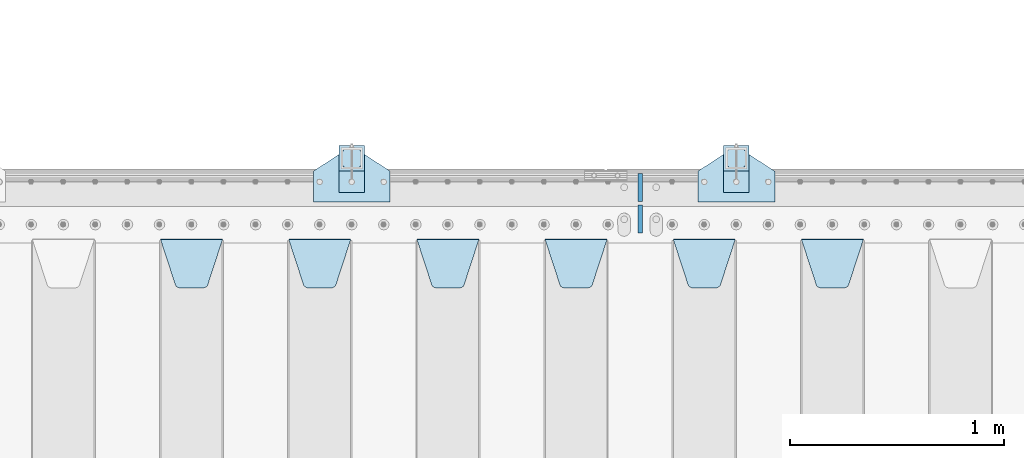
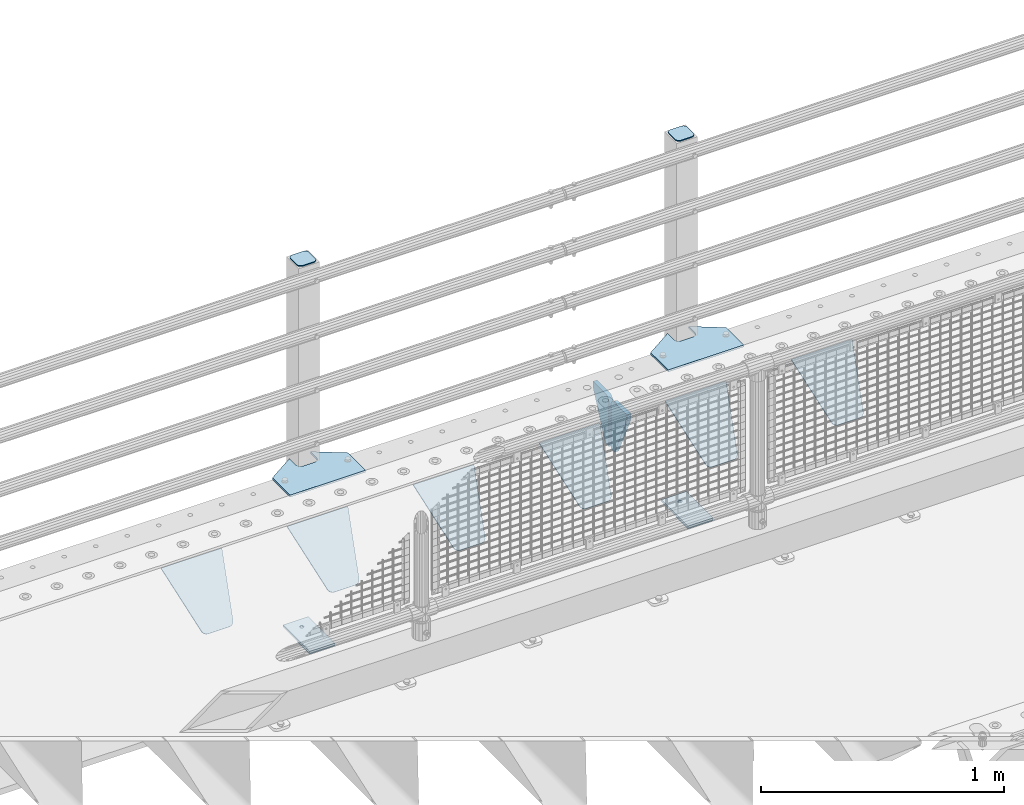
# One storey, part 175 of 208: 16 plates.
"""IFC2X3 building model written with IfcOpenShell, lengths in millimetres."""

from ifc_helpers import new_model, si_unit, frame, origin_with_axes, place, context, subcontext, project, spatial, faceted_brep, material, type_object, element, save


model = new_model("IFC2X3")

# Units and contexts
model_context = context("Model", 3, precision=1e-05, world=origin_with_axes())
body_context = subcontext(model_context, "Body", "Model", "MODEL_VIEW")
ifc_project = project(units=[si_unit("LENGTHUNIT", "METRE", prefix="MILLI"), si_unit("AREAUNIT", "SQUARE_METRE"), si_unit("VOLUMEUNIT", "CUBIC_METRE"), si_unit("MASSUNIT", "GRAM", prefix="KILO"), si_unit("TIMEUNIT", "SECOND"), si_unit("PLANEANGLEUNIT", "RADIAN"), si_unit("SOLIDANGLEUNIT", "STERADIAN"), si_unit("THERMODYNAMICTEMPERATUREUNIT", "DEGREE_CELSIUS"), si_unit("LUMINOUSINTENSITYUNIT", "LUMEN")], contexts=[model_context])

# Site, building, storey
site_placement = place(None, origin_with_axes())
site = spatial("IfcSite", under=ifc_project, at=site_placement, CompositionType="ELEMENT")
building_placement = place(site_placement, origin_with_axes())
building = spatial("IfcBuilding", under=site, at=building_placement, Name="Standard", CompositionType="ELEMENT")
storey_placement = place(building_placement, origin_with_axes())
storey = spatial("IfcBuildingStorey", under=building, at=storey_placement, Name="Undefined", CompositionType="ELEMENT", Elevation=0.0)

# Plates
ifc_material_1 = material(Name="STEEL/S355N")
plate_type_1 = type_object("IfcPlateType", PredefinedType="NOTDEFINED")
plate_1_placement = place(storey_placement, frame((-36195.0, 5831.76776695596, -1.76776695296758), z_axis=(0.0, -0.707106781186548, -0.707106781186547), x_axis=(1.0, 0.0, 0.0)))
element("IfcPlate", 1, at=plate_1_placement, inside=storey, type_object=plate_type_1, material=ifc_material_1, context=body_context, shape_type="Brep", body=[
    faceted_brep([(0.0, -2.5, 0.0), (69.345504679477, -2.5, 300.17173142483), (69.345504679477, 2.5, 300.17173142483), (0.0, 2.5, 0.0), (70.9274061199576, -2.5, 304.897442415399), (70.9274061199576, 2.5, 304.8974424154), (73.3818627772307, -2.5, 309.234538108527), (73.3818627772307, 2.5, 309.234538108527), (76.6187032999551, -2.5, 313.023683126103), (76.6187032999551, 2.5, 313.023683126103), (80.5190132704993, -2.5, 316.125672595371), (80.5190132704993, 2.5, 316.125672595371), (84.9395038596849, -2.5, 318.426546230476), (84.9395038596849, 2.50000000000091, 318.426546230476), (89.7177759439219, -2.5, 319.841774983275), (89.7177759439219, 2.50000000000091, 319.841774983275), (94.678286292652, -2.49999999999909, 320.319366455078), (94.678286292652, 2.5, 320.319366455078), (195.321713707348, -2.49999999999909, 320.319366455078), (195.321713707348, 2.5, 320.319366455078), (200.282224056078, -2.5, 319.841774983275), (200.282224056078, 2.5, 319.841774983274), (205.060496140315, -2.5, 318.426546230475), (205.060496140315, 2.5, 318.426546230475), (209.480986729501, -2.5, 316.125672595371), (209.480986729501, 2.50000000000091, 316.125672595371), (213.381296700045, -2.5, 313.023683126102), (213.381296700045, 2.5, 313.023683126102), (216.618137222769, -2.5, 309.234538108526), (216.618137222769, 2.5, 309.234538108527), (219.072593880042, -2.5, 304.897442415399), (219.072593880042, 2.5, 304.897442415399), (220.654495320523, -2.5, 300.17173142483), (220.654495320523, 2.5, 300.17173142483), (290.0, -2.5, 0.0), (290.0, 2.5, 0.0)], [[[0, 1, 2, 3]], [[1, 4, 5, 2]], [[4, 6, 7, 5]], [[6, 8, 9, 7]], [[8, 10, 11, 9]], [[10, 12, 13, 11]], [[12, 14, 15, 13]], [[14, 16, 17, 15]], [[16, 18, 19, 17]], [[18, 20, 21, 19]], [[20, 22, 23, 21]], [[22, 24, 25, 23]], [[24, 26, 27, 25]], [[26, 28, 29, 27]], [[28, 30, 31, 29]], [[30, 32, 33, 31]], [[32, 34, 35, 33]], [[34, 0, 3, 35]], [[5, 7, 9, 11, 13, 15, 17, 19, 21, 23, 25, 27, 29, 31, 33, 35, 3, 2]], [[34, 32, 30, 28, 26, 24, 22, 20, 18, 16, 14, 12, 10, 8, 6, 4, 1, 0]]]),
])
plate_2_placement = place(storey_placement, frame((-36795.0, 5831.76776695596, -1.76776695296758), z_axis=(0.0, -0.707106781186548, -0.707106781186547), x_axis=(1.0, 0.0, 0.0)))
element("IfcPlate", 2, at=plate_2_placement, inside=storey, type_object=plate_type_1, material=ifc_material_1, context=body_context, shape_type="Brep", body=[
    faceted_brep([(0.0, -2.5, 0.0), (69.345504679477, -2.5, 300.17173142483), (69.345504679477, 2.5, 300.17173142483), (0.0, 2.5, 0.0), (70.9274061199576, -2.5, 304.897442415399), (70.9274061199576, 2.5, 304.8974424154), (73.3818627772307, -2.5, 309.234538108527), (73.3818627772307, 2.5, 309.234538108527), (76.6187032999551, -2.5, 313.023683126103), (76.6187032999551, 2.5, 313.023683126103), (80.5190132704993, -2.5, 316.125672595371), (80.5190132704993, 2.5, 316.125672595371), (84.9395038596849, -2.5, 318.426546230476), (84.9395038596849, 2.50000000000091, 318.426546230476), (89.7177759439219, -2.5, 319.841774983275), (89.7177759439219, 2.50000000000091, 319.841774983275), (94.678286292652, -2.49999999999909, 320.319366455078), (94.678286292652, 2.5, 320.319366455078), (195.321713707348, -2.49999999999909, 320.319366455078), (195.321713707348, 2.5, 320.319366455078), (200.282224056078, -2.5, 319.841774983275), (200.282224056078, 2.5, 319.841774983274), (205.060496140315, -2.5, 318.426546230475), (205.060496140315, 2.5, 318.426546230475), (209.480986729501, -2.5, 316.125672595371), (209.480986729501, 2.50000000000091, 316.125672595371), (213.381296700045, -2.5, 313.023683126102), (213.381296700045, 2.5, 313.023683126102), (216.618137222769, -2.5, 309.234538108526), (216.618137222769, 2.5, 309.234538108527), (219.072593880042, -2.5, 304.897442415399), (219.072593880042, 2.5, 304.897442415399), (220.654495320523, -2.5, 300.17173142483), (220.654495320523, 2.5, 300.17173142483), (290.0, -2.5, 0.0), (290.0, 2.5, 0.0)], [[[0, 1, 2, 3]], [[1, 4, 5, 2]], [[4, 6, 7, 5]], [[6, 8, 9, 7]], [[8, 10, 11, 9]], [[10, 12, 13, 11]], [[12, 14, 15, 13]], [[14, 16, 17, 15]], [[16, 18, 19, 17]], [[18, 20, 21, 19]], [[20, 22, 23, 21]], [[22, 24, 25, 23]], [[24, 26, 27, 25]], [[26, 28, 29, 27]], [[28, 30, 31, 29]], [[30, 32, 33, 31]], [[32, 34, 35, 33]], [[34, 0, 3, 35]], [[5, 7, 9, 11, 13, 15, 17, 19, 21, 23, 25, 27, 29, 31, 33, 35, 3, 2]], [[34, 32, 30, 28, 26, 24, 22, 20, 18, 16, 14, 12, 10, 8, 6, 4, 1, 0]]]),
])
plate_3_placement = place(storey_placement, frame((-37395.0, 5831.76776695596, -1.76776695296758), z_axis=(0.0, -0.707106781186548, -0.707106781186547), x_axis=(1.0, 0.0, 0.0)))
element("IfcPlate", 3, at=plate_3_placement, inside=storey, type_object=plate_type_1, material=ifc_material_1, context=body_context, shape_type="Brep", body=[
    faceted_brep([(0.0, -2.5, 0.0), (69.345504679477, -2.5, 300.17173142483), (69.345504679477, 2.5, 300.17173142483), (0.0, 2.5, 0.0), (70.9274061199576, -2.5, 304.897442415399), (70.9274061199576, 2.5, 304.8974424154), (73.3818627772307, -2.5, 309.234538108527), (73.3818627772307, 2.5, 309.234538108527), (76.6187032999551, -2.5, 313.023683126103), (76.6187032999551, 2.5, 313.023683126103), (80.5190132704993, -2.5, 316.125672595371), (80.5190132704993, 2.5, 316.125672595371), (84.9395038596849, -2.5, 318.426546230476), (84.9395038596849, 2.50000000000091, 318.426546230476), (89.7177759439219, -2.5, 319.841774983275), (89.7177759439219, 2.50000000000091, 319.841774983275), (94.678286292652, -2.49999999999909, 320.319366455078), (94.678286292652, 2.5, 320.319366455078), (195.321713707348, -2.49999999999909, 320.319366455078), (195.321713707348, 2.5, 320.319366455078), (200.282224056078, -2.5, 319.841774983275), (200.282224056078, 2.5, 319.841774983274), (205.060496140315, -2.5, 318.426546230475), (205.060496140315, 2.5, 318.426546230475), (209.480986729501, -2.5, 316.125672595371), (209.480986729501, 2.50000000000091, 316.125672595371), (213.381296700045, -2.5, 313.023683126102), (213.381296700045, 2.5, 313.023683126102), (216.618137222769, -2.5, 309.234538108526), (216.618137222769, 2.5, 309.234538108527), (219.072593880042, -2.5, 304.897442415399), (219.072593880042, 2.5, 304.897442415399), (220.654495320523, -2.5, 300.17173142483), (220.654495320523, 2.5, 300.17173142483), (290.0, -2.5, 0.0), (290.0, 2.5, 0.0)], [[[0, 1, 2, 3]], [[1, 4, 5, 2]], [[4, 6, 7, 5]], [[6, 8, 9, 7]], [[8, 10, 11, 9]], [[10, 12, 13, 11]], [[12, 14, 15, 13]], [[14, 16, 17, 15]], [[16, 18, 19, 17]], [[18, 20, 21, 19]], [[20, 22, 23, 21]], [[22, 24, 25, 23]], [[24, 26, 27, 25]], [[26, 28, 29, 27]], [[28, 30, 31, 29]], [[30, 32, 33, 31]], [[32, 34, 35, 33]], [[34, 0, 3, 35]], [[5, 7, 9, 11, 13, 15, 17, 19, 21, 23, 25, 27, 29, 31, 33, 35, 3, 2]], [[34, 32, 30, 28, 26, 24, 22, 20, 18, 16, 14, 12, 10, 8, 6, 4, 1, 0]]]),
])
plate_4_placement = place(storey_placement, frame((-37995.0, 5831.76776695596, -1.76776695296758), z_axis=(0.0, -0.707106781186548, -0.707106781186547), x_axis=(1.0, 0.0, 0.0)))
element("IfcPlate", 4, at=plate_4_placement, inside=storey, type_object=plate_type_1, material=ifc_material_1, context=body_context, shape_type="Brep", body=[
    faceted_brep([(0.0, -2.5, 0.0), (69.345504679477, -2.5, 300.17173142483), (69.345504679477, 2.5, 300.17173142483), (0.0, 2.5, 0.0), (70.9274061199576, -2.5, 304.897442415399), (70.9274061199576, 2.5, 304.8974424154), (73.3818627772307, -2.5, 309.234538108527), (73.3818627772307, 2.5, 309.234538108527), (76.6187032999551, -2.5, 313.023683126103), (76.6187032999551, 2.5, 313.023683126103), (80.5190132704993, -2.5, 316.125672595371), (80.5190132704993, 2.5, 316.125672595371), (84.9395038596849, -2.5, 318.426546230476), (84.9395038596849, 2.50000000000091, 318.426546230476), (89.7177759439219, -2.5, 319.841774983275), (89.7177759439219, 2.50000000000091, 319.841774983275), (94.678286292652, -2.49999999999909, 320.319366455078), (94.678286292652, 2.5, 320.319366455078), (195.321713707348, -2.49999999999909, 320.319366455078), (195.321713707348, 2.5, 320.319366455078), (200.282224056078, -2.5, 319.841774983275), (200.282224056078, 2.5, 319.841774983274), (205.060496140315, -2.5, 318.426546230475), (205.060496140315, 2.5, 318.426546230475), (209.480986729501, -2.5, 316.125672595371), (209.480986729501, 2.50000000000091, 316.125672595371), (213.381296700045, -2.5, 313.023683126102), (213.381296700045, 2.5, 313.023683126102), (216.618137222769, -2.5, 309.234538108526), (216.618137222769, 2.5, 309.234538108527), (219.072593880042, -2.5, 304.897442415399), (219.072593880042, 2.5, 304.897442415399), (220.654495320523, -2.5, 300.17173142483), (220.654495320523, 2.5, 300.17173142483), (290.0, -2.5, 0.0), (290.0, 2.5, 0.0)], [[[0, 1, 2, 3]], [[1, 4, 5, 2]], [[4, 6, 7, 5]], [[6, 8, 9, 7]], [[8, 10, 11, 9]], [[10, 12, 13, 11]], [[12, 14, 15, 13]], [[14, 16, 17, 15]], [[16, 18, 19, 17]], [[18, 20, 21, 19]], [[20, 22, 23, 21]], [[22, 24, 25, 23]], [[24, 26, 27, 25]], [[26, 28, 29, 27]], [[28, 30, 31, 29]], [[30, 32, 33, 31]], [[32, 34, 35, 33]], [[34, 0, 3, 35]], [[5, 7, 9, 11, 13, 15, 17, 19, 21, 23, 25, 27, 29, 31, 33, 35, 3, 2]], [[34, 32, 30, 28, 26, 24, 22, 20, 18, 16, 14, 12, 10, 8, 6, 4, 1, 0]]]),
])
plate_5_placement = place(storey_placement, frame((-38595.0, 5831.76776695596, -1.76776695296758), z_axis=(0.0, -0.707106781186548, -0.707106781186547), x_axis=(1.0, 0.0, 0.0)))
element("IfcPlate", 5, at=plate_5_placement, inside=storey, type_object=plate_type_1, material=ifc_material_1, context=body_context, shape_type="Brep", body=[
    faceted_brep([(0.0, -2.5, 0.0), (69.345504679477, -2.5, 300.17173142483), (69.345504679477, 2.5, 300.17173142483), (0.0, 2.5, 0.0), (70.9274061199576, -2.5, 304.897442415399), (70.9274061199576, 2.5, 304.8974424154), (73.3818627772307, -2.5, 309.234538108527), (73.3818627772307, 2.5, 309.234538108527), (76.6187032999551, -2.5, 313.023683126103), (76.6187032999551, 2.5, 313.023683126103), (80.5190132704993, -2.5, 316.125672595371), (80.5190132704993, 2.5, 316.125672595371), (84.9395038596849, -2.5, 318.426546230476), (84.9395038596849, 2.50000000000091, 318.426546230476), (89.7177759439219, -2.5, 319.841774983275), (89.7177759439219, 2.50000000000091, 319.841774983275), (94.678286292652, -2.49999999999909, 320.319366455078), (94.678286292652, 2.5, 320.319366455078), (195.321713707348, -2.49999999999909, 320.319366455078), (195.321713707348, 2.5, 320.319366455078), (200.282224056078, -2.5, 319.841774983275), (200.282224056078, 2.5, 319.841774983274), (205.060496140315, -2.5, 318.426546230475), (205.060496140315, 2.5, 318.426546230475), (209.480986729501, -2.5, 316.125672595371), (209.480986729501, 2.50000000000091, 316.125672595371), (213.381296700045, -2.5, 313.023683126102), (213.381296700045, 2.5, 313.023683126102), (216.618137222769, -2.5, 309.234538108526), (216.618137222769, 2.5, 309.234538108527), (219.072593880042, -2.5, 304.897442415399), (219.072593880042, 2.5, 304.897442415399), (220.654495320523, -2.5, 300.17173142483), (220.654495320523, 2.5, 300.17173142483), (290.0, -2.5, 0.0), (290.0, 2.5, 0.0)], [[[0, 1, 2, 3]], [[1, 4, 5, 2]], [[4, 6, 7, 5]], [[6, 8, 9, 7]], [[8, 10, 11, 9]], [[10, 12, 13, 11]], [[12, 14, 15, 13]], [[14, 16, 17, 15]], [[16, 18, 19, 17]], [[18, 20, 21, 19]], [[20, 22, 23, 21]], [[22, 24, 25, 23]], [[24, 26, 27, 25]], [[26, 28, 29, 27]], [[28, 30, 31, 29]], [[30, 32, 33, 31]], [[32, 34, 35, 33]], [[34, 0, 3, 35]], [[5, 7, 9, 11, 13, 15, 17, 19, 21, 23, 25, 27, 29, 31, 33, 35, 3, 2]], [[34, 32, 30, 28, 26, 24, 22, 20, 18, 16, 14, 12, 10, 8, 6, 4, 1, 0]]]),
])
plate_6_placement = place(storey_placement, frame((-39195.0, 5831.76776695596, -1.76776695296758), z_axis=(0.0, -0.707106781186548, -0.707106781186547), x_axis=(1.0, 0.0, 0.0)))
element("IfcPlate", 6, at=plate_6_placement, inside=storey, type_object=plate_type_1, material=ifc_material_1, context=body_context, shape_type="Brep", body=[
    faceted_brep([(0.0, -2.5, 0.0), (69.345504679477, -2.5, 300.17173142483), (69.345504679477, 2.5, 300.17173142483), (0.0, 2.5, 0.0), (70.9274061199576, -2.5, 304.897442415399), (70.9274061199576, 2.5, 304.8974424154), (73.3818627772307, -2.5, 309.234538108527), (73.3818627772307, 2.5, 309.234538108527), (76.6187032999551, -2.5, 313.023683126103), (76.6187032999551, 2.5, 313.023683126103), (80.5190132704993, -2.5, 316.125672595371), (80.5190132704993, 2.5, 316.125672595371), (84.9395038596849, -2.5, 318.426546230476), (84.9395038596849, 2.50000000000091, 318.426546230476), (89.7177759439219, -2.5, 319.841774983275), (89.7177759439219, 2.50000000000091, 319.841774983275), (94.678286292652, -2.49999999999909, 320.319366455078), (94.678286292652, 2.5, 320.319366455078), (195.321713707348, -2.49999999999909, 320.319366455078), (195.321713707348, 2.5, 320.319366455078), (200.282224056078, -2.5, 319.841774983275), (200.282224056078, 2.5, 319.841774983274), (205.060496140315, -2.5, 318.426546230475), (205.060496140315, 2.5, 318.426546230475), (209.480986729501, -2.5, 316.125672595371), (209.480986729501, 2.50000000000091, 316.125672595371), (213.381296700045, -2.5, 313.023683126102), (213.381296700045, 2.5, 313.023683126102), (216.618137222769, -2.5, 309.234538108526), (216.618137222769, 2.5, 309.234538108527), (219.072593880042, -2.5, 304.897442415399), (219.072593880042, 2.5, 304.897442415399), (220.654495320523, -2.5, 300.17173142483), (220.654495320523, 2.5, 300.17173142483), (290.0, -2.5, 0.0), (290.0, 2.5, 0.0)], [[[0, 1, 2, 3]], [[1, 4, 5, 2]], [[4, 6, 7, 5]], [[6, 8, 9, 7]], [[8, 10, 11, 9]], [[10, 12, 13, 11]], [[12, 14, 15, 13]], [[14, 16, 17, 15]], [[16, 18, 19, 17]], [[18, 20, 21, 19]], [[20, 22, 23, 21]], [[22, 24, 25, 23]], [[24, 26, 27, 25]], [[26, 28, 29, 27]], [[28, 30, 31, 29]], [[30, 32, 33, 31]], [[32, 34, 35, 33]], [[34, 0, 3, 35]], [[5, 7, 9, 11, 13, 15, 17, 19, 21, 23, 25, 27, 29, 31, 33, 35, 3, 2]], [[34, 32, 30, 28, 26, 24, 22, 20, 18, 16, 14, 12, 10, 8, 6, 4, 1, 0]]]),
])
plate_type_2 = type_object("IfcPlateType", PredefinedType="NOTDEFINED")
for number, where, z_axis, x_axis in (
    (7, (-36950.0, 6140.0, -30.0), (0.0, 0.0, -1.0), (0.0, -1.0, 0.0)),
    (8, (-36950.0, 5860.0, -30.0), (0.0, 0.0, -1.0), (0.0, 1.0, 0.0)),
):
    element("IfcPlate", number, at=place(storey_placement, frame(where, z_axis=z_axis, x_axis=x_axis)), inside=storey, type_object=plate_type_2, material=ifc_material_1, context=body_context, shape_type="Brep", body=[
        faceted_brep([(0.0, -10.0, 0.0), (0.0, -10.0, 30.0), (0.0, 10.0, 30.0), (0.0, 10.0, 0.0), (102.0, -10.0, 250.0), (102.0, 10.0, 250.0), (132.0, -10.0, 250.0), (132.0, 10.0, 250.0), (132.0, -10.0, 30.0), (132.0, 10.0, 30.0), (131.544232590366, -10.0, 24.790554669992), (131.544232590366, 10.0, 24.790554669992), (130.190778623577, -10.0, 19.7393957002299), (130.190778623577, 10.0, 19.7393957002299), (127.980762113533, -10.0, 15.0), (127.980762113533, 10.0, 15.0), (124.981333293569, -10.0, 10.7163717094038), (124.981333293569, 10.0, 10.7163717094038), (121.283628290596, -10.0, 7.01866670643062), (121.283628290596, 10.0, 7.01866670643062), (117.0, -10.0, 4.01923788646684), (117.0, 10.0, 4.01923788646684), (112.26060429977, -10.0, 1.80922137642278), (112.26060429977, 10.0, 1.80922137642278), (107.209445330008, -10.0, 0.455767409633722), (107.209445330008, 10.0, 0.455767409633722), (102.0, -10.0, 0.0), (102.0, 10.0, 0.0)], [[[0, 1, 2, 3]], [[1, 4, 5, 2]], [[4, 6, 7, 5]], [[6, 8, 9, 7]], [[8, 10, 11, 9]], [[10, 12, 13, 11]], [[12, 14, 15, 13]], [[14, 16, 17, 15]], [[16, 18, 19, 17]], [[18, 20, 21, 19]], [[20, 22, 23, 21]], [[22, 24, 25, 23]], [[24, 26, 27, 25]], [[26, 0, 3, 27]], [[5, 7, 9, 11, 13, 15, 17, 19, 21, 23, 25, 27, 3, 2]], [[26, 24, 22, 20, 18, 16, 14, 12, 10, 8, 6, 4, 1, 0]]]),
    ])
ifc_material_2 = material(Name="STEEL/S355J2")
plate_type_3 = type_object("IfcPlateType", PredefinedType="NOTDEFINED")
plate_7_placement = place(storey_placement, frame((-36680.0, 6005.0, 5.00000000004911), z_axis=(0.0, 1.0, 0.0), x_axis=(1.0, 0.0, 0.0)))
element("IfcPlate", 9, at=plate_7_placement, inside=storey, type_object=plate_type_3, material=ifc_material_2, context=body_context, shape_type="Brep", body=[
    faceted_brep([(0.0, -5.0, 0.0), (2.31396552408114e-06, -5.0, 145.0), (2.31396552408114e-06, 5.0, 145.0), (0.0, 5.0, 0.0), (130.0, -5.0, 230.0), (130.0, 5.0, 230.0), (130.0, -5.0, 180.0), (130.0, 5.0, 180.0), (130.48036798992, -5.0, 175.122741949597), (130.48036798992, 5.0, 175.122741949597), (131.903011687216, -5.0, 170.432914190873), (131.903011687216, 5.0, 170.432914190873), (134.213259692435, -5.0, 166.11074417451), (134.213259692435, 5.0, 166.11074417451), (137.322330470335, -5.0, 162.322330470336), (137.322330470335, 5.0, 162.322330470336), (141.110744174512, -5.0, 159.213259692437), (141.110744174512, 5.0, 159.213259692437), (145.432914190871, -5.0, 156.903011687218), (145.432914190871, 5.0, 156.903011687218), (150.122741949595, -5.0, 155.48036798992), (150.122741949595, 5.0, 155.48036798992), (155.0, -5.0, 155.0), (155.0, 5.0, 155.0), (205.0, -5.0, 155.0), (205.0, 5.0, 155.0), (209.877258050405, -5.0, 155.48036798992), (209.877258050405, 5.0, 155.48036798992), (214.567085809129, -5.0, 156.903011687218), (214.567085809129, 5.0, 156.903011687218), (218.889255825488, -5.0, 159.213259692437), (218.889255825488, 5.0, 159.213259692437), (222.677669529665, -5.0, 162.322330470336), (222.677669529665, 5.0, 162.322330470336), (225.786740307565, -5.0, 166.11074417451), (225.786740307565, 5.0, 166.11074417451), (228.096988312784, -5.0, 170.432914190873), (228.096988312784, 5.0, 170.432914190873), (229.51963201008, -5.0, 175.122741949597), (229.51963201008, 5.0, 175.122741949597), (230.0, -5.0, 180.0), (230.0, 5.0, 180.0), (230.0, -5.0, 230.0), (230.0, 5.0, 230.0), (360.0, -5.0, 145.0), (360.0, 5.0, 145.0), (360.0, -5.0, -7.27595761418343e-12), (360.0, 5.0, -7.27595761418343e-12)], [[[0, 1, 2, 3]], [[1, 4, 5, 2]], [[4, 6, 7, 5]], [[6, 8, 9, 7]], [[8, 10, 11, 9]], [[10, 12, 13, 11]], [[12, 14, 15, 13]], [[14, 16, 17, 15]], [[16, 18, 19, 17]], [[18, 20, 21, 19]], [[20, 22, 23, 21]], [[22, 24, 25, 23]], [[24, 26, 27, 25]], [[26, 28, 29, 27]], [[28, 30, 31, 29]], [[30, 32, 33, 31]], [[32, 34, 35, 33]], [[34, 36, 37, 35]], [[36, 38, 39, 37]], [[38, 40, 41, 39]], [[40, 42, 43, 41]], [[42, 44, 45, 43]], [[44, 46, 47, 45]], [[46, 0, 3, 47]], [[5, 7, 9, 11, 13, 15, 17, 19, 21, 23, 25, 27, 29, 31, 33, 35, 37, 39, 41, 43, 45, 47, 3, 2]], [[46, 44, 42, 40, 38, 36, 34, 32, 30, 28, 26, 24, 22, 20, 18, 16, 14, 12, 10, 8, 6, 4, 1, 0]]]),
])
plate_8_placement = place(storey_placement, frame((-38480.0, 6005.0, 5.00000000004911), z_axis=(0.0, 1.0, 0.0), x_axis=(1.0, 0.0, 0.0)))
element("IfcPlate", 10, at=plate_8_placement, inside=storey, type_object=plate_type_3, material=ifc_material_2, context=body_context, shape_type="Brep", body=[
    faceted_brep([(0.0, -5.0, 0.0), (2.31396552408114e-06, -5.0, 145.0), (2.31396552408114e-06, 5.0, 145.0), (0.0, 5.0, 0.0), (130.0, -5.0, 230.0), (130.0, 5.0, 230.0), (130.0, -5.0, 180.0), (130.0, 5.0, 180.0), (130.48036798992, -5.0, 175.122741949597), (130.48036798992, 5.0, 175.122741949597), (131.903011687216, -5.0, 170.432914190873), (131.903011687216, 5.0, 170.432914190873), (134.213259692435, -5.0, 166.11074417451), (134.213259692435, 5.0, 166.11074417451), (137.322330470335, -5.0, 162.322330470336), (137.322330470335, 5.0, 162.322330470336), (141.110744174512, -5.0, 159.213259692437), (141.110744174512, 5.0, 159.213259692437), (145.432914190871, -5.0, 156.903011687218), (145.432914190871, 5.0, 156.903011687218), (150.122741949595, -5.0, 155.48036798992), (150.122741949595, 5.0, 155.48036798992), (155.0, -5.0, 155.0), (155.0, 5.0, 155.0), (205.0, -5.0, 155.0), (205.0, 5.0, 155.0), (209.877258050405, -5.0, 155.48036798992), (209.877258050405, 5.0, 155.48036798992), (214.567085809129, -5.0, 156.903011687218), (214.567085809129, 5.0, 156.903011687218), (218.889255825488, -5.0, 159.213259692437), (218.889255825488, 5.0, 159.213259692437), (222.677669529665, -5.0, 162.322330470336), (222.677669529665, 5.0, 162.322330470336), (225.786740307565, -5.0, 166.11074417451), (225.786740307565, 5.0, 166.11074417451), (228.096988312784, -5.0, 170.432914190873), (228.096988312784, 5.0, 170.432914190873), (229.51963201008, -5.0, 175.122741949597), (229.51963201008, 5.0, 175.122741949597), (230.0, -5.0, 180.0), (230.0, 5.0, 180.0), (230.0, -5.0, 230.0), (230.0, 5.0, 230.0), (360.0, -5.0, 145.0), (360.0, 5.0, 145.0), (360.0, -5.0, -7.27595761418343e-12), (360.0, 5.0, -7.27595761418343e-12)], [[[0, 1, 2, 3]], [[1, 4, 5, 2]], [[4, 6, 7, 5]], [[6, 8, 9, 7]], [[8, 10, 11, 9]], [[10, 12, 13, 11]], [[12, 14, 15, 13]], [[14, 16, 17, 15]], [[16, 18, 19, 17]], [[18, 20, 21, 19]], [[20, 22, 23, 21]], [[22, 24, 25, 23]], [[24, 26, 27, 25]], [[26, 28, 29, 27]], [[28, 30, 31, 29]], [[30, 32, 33, 31]], [[32, 34, 35, 33]], [[34, 36, 37, 35]], [[36, 38, 39, 37]], [[38, 40, 41, 39]], [[40, 42, 43, 41]], [[42, 44, 45, 43]], [[44, 46, 47, 45]], [[46, 0, 3, 47]], [[5, 7, 9, 11, 13, 15, 17, 19, 21, 23, 25, 27, 29, 31, 33, 35, 37, 39, 41, 43, 45, 47, 3, 2]], [[46, 44, 42, 40, 38, 36, 34, 32, 30, 28, 26, 24, 22, 20, 18, 16, 14, 12, 10, 8, 6, 4, 1, 0]]]),
])
plate_type_4 = type_object("IfcPlateType", PredefinedType="NOTDEFINED")
for number, where, z_axis, x_axis in (
    (11, (-36559.9999999999, 6050.00000000021, -850.000000000002), (0.0, 1.0, 0.0), (1.0, 0.0, 0.0)),
    (12, (-38359.9999999999, 6050.00000000021, -850.000000000002), (0.0, 1.0, 0.0), (1.0, 0.0, 0.0)),
):
    element("IfcPlate", number, at=place(storey_placement, frame(where, z_axis=z_axis, x_axis=x_axis)), inside=storey, type_object=plate_type_4, material=ifc_material_2, context=body_context, shape_type="Brep", body=[
        faceted_brep([(66.3639610305399, -5.0, 163.636038969112), (66.3639610305399, 5.0, 163.636038969112), (59.9999999998618, 5.0, 160.999999999791), (59.9999999998618, -5.0, 160.999999999791), (53.6360389691836, 5.0, 163.636038969112), (53.6360389691836, -5.0, 163.636038969112), (50.9999999998618, 5.0, 169.999999999791), (50.9999999998618, -5.0, 169.999999999791), (53.6360389691836, 5.0, 176.36396103047), (53.6360389691836, -5.0, 176.36396103047), (59.9999999998618, 5.0, 178.999999999791), (59.9999999998618, -5.0, 178.999999999791), (66.3639610305399, 5.0, 176.36396103047), (66.3639610305399, -5.0, 176.36396103047), (68.9999999998618, 5.0, 169.999999999791), (68.9999999998618, -5.0, 169.999999999791), (120.0, -5.0, 0.0), (120.0, -5.0, 220.0), (0.0, -5.0, 220.0), (0.0, -5.0, 0.0), (0.0, 5.0, 0.0), (120.0, 5.0, 0.0), (120.0, 5.0, 220.0), (0.0, 5.0, 220.0)], [[[0, 1, 2, 3]], [[3, 2, 4, 5]], [[5, 4, 6, 7]], [[7, 6, 8, 9]], [[9, 8, 10, 11]], [[11, 10, 12, 13]], [[13, 12, 14, 15]], [[15, 14, 1, 0]], [[16, 17, 18, 19], [3, 5, 7, 9, 11, 13, 15, 0]], [[16, 19, 20, 21]], [[17, 16, 21, 22]], [[18, 17, 22, 23]], [[19, 18, 23, 20]], [[22, 21, 20, 23], [10, 8, 6, 4, 2, 1, 14, 12]]]),
    ])
plate_type_5 = type_object("IfcPlateType", PredefinedType="NOTDEFINED")
plate_9_placement = place(storey_placement, frame((-36455.9999999999, 6166.00000000021, 1012.50000000001), z_axis=(0.0, 1.0, 0.0), x_axis=(-1.0, 0.0, 0.0)))
element("IfcPlate", 13, at=plate_9_placement, inside=storey, type_object=plate_type_5, material=ifc_material_2, context=body_context, shape_type="Brep", body=[
    faceted_brep([(0.0, -2.5, 19.0), (0.0, -2.5, 69.0), (0.0, 2.5, 69.0), (0.0, 2.5, 19.0), (0.476369668544066, -2.5, 73.2278977451697), (0.476369668544066, 2.5, 73.2278977451697), (1.88159150985302, -2.5, 77.2437910432336), (1.88159150985302, 2.5, 77.2437910432336), (4.14520183310742, -2.5, 80.8463062353158), (4.14520183310742, 2.5, 80.8463062353158), (7.15369376468516, -2.5, 83.8547981668926), (7.15369376468516, 2.5, 83.8547981668926), (10.7562089567655, -2.5, 86.1184084901461), (10.7562089567655, 2.5, 86.1184084901461), (14.7721022548285, -2.5, 87.523630331455), (14.7721022548285, 2.5, 87.523630331455), (19.0, -2.5, 88.0), (19.0, 2.5, 88.0), (69.0, -2.5, 88.0), (69.0, 2.5, 88.0), (73.2278977451715, -2.5, 87.523630331455), (73.2278977451715, 2.5, 87.523630331455), (77.2437910432345, -2.5, 86.1184084901461), (77.2437910432345, 2.5, 86.1184084901461), (80.8463062353148, -2.5, 83.8547981668926), (80.8463062353148, 2.5, 83.8547981668926), (83.8547981668926, -2.5, 80.8463062353158), (83.8547981668926, 2.5, 80.8463062353158), (86.118408490147, -2.5, 77.2437910432336), (86.118408490147, 2.5, 77.2437910432336), (87.5236303314559, -2.5, 73.2278977451697), (87.5236303314559, 2.5, 73.2278977451697), (88.0, -2.5, 69.0), (88.0, 2.5, 69.0), (88.0, -2.5, 19.0), (88.0, 2.5, 19.0), (87.5236303314559, -2.5, 14.7721022548303), (87.5236303314559, 2.5, 14.7721022548303), (86.118408490147, -2.5, 10.7562089567664), (86.118408490147, 2.5, 10.7562089567664), (83.8547981668926, -2.5, 7.15369376468425), (83.8547981668926, 2.5, 7.15369376468425), (80.8463062353148, -2.5, 4.14520183310742), (80.8463062353148, 2.5, 4.14520183310742), (77.2437910432345, -2.5, 1.88159150985393), (77.2437910432345, 2.5, 1.88159150985393), (73.2278977451715, -2.5, 0.476369668544976), (73.2278977451715, 2.5, 0.476369668544976), (69.0, -2.5, 0.0), (69.0, 2.5, 0.0), (19.0, -2.5, 0.0), (19.0, 2.5, 0.0), (14.7721022548285, -2.5, 0.476369668544976), (14.7721022548285, 2.5, 0.476369668544976), (10.7562089567655, -2.5, 1.88159150985393), (10.7562089567655, 2.5, 1.88159150985393), (7.15369376468516, -2.5, 4.14520183310742), (7.15369376468516, 2.5, 4.14520183310742), (4.14520183310742, -2.5, 7.15369376468425), (4.14520183310742, 2.5, 7.15369376468425), (1.88159150985302, -2.5, 10.7562089567664), (1.88159150985302, 2.5, 10.7562089567664), (0.476369668544066, -2.5, 14.7721022548303), (0.476369668544066, 2.5, 14.7721022548303)], [[[0, 1, 2, 3]], [[1, 4, 5, 2]], [[4, 6, 7, 5]], [[6, 8, 9, 7]], [[8, 10, 11, 9]], [[10, 12, 13, 11]], [[12, 14, 15, 13]], [[14, 16, 17, 15]], [[16, 18, 19, 17]], [[18, 20, 21, 19]], [[20, 22, 23, 21]], [[22, 24, 25, 23]], [[24, 26, 27, 25]], [[26, 28, 29, 27]], [[28, 30, 31, 29]], [[30, 32, 33, 31]], [[32, 34, 35, 33]], [[34, 36, 37, 35]], [[36, 38, 39, 37]], [[38, 40, 41, 39]], [[40, 42, 43, 41]], [[42, 44, 45, 43]], [[44, 46, 47, 45]], [[46, 48, 49, 47]], [[48, 50, 51, 49]], [[50, 52, 53, 51]], [[52, 54, 55, 53]], [[54, 56, 57, 55]], [[56, 58, 59, 57]], [[58, 60, 61, 59]], [[60, 62, 63, 61]], [[62, 0, 3, 63]], [[5, 7, 9, 11, 13, 15, 17, 19, 21, 23, 25, 27, 29, 31, 33, 35, 37, 39, 41, 43, 45, 47, 49, 51, 53, 55, 57, 59, 61, 63, 3, 2]], [[62, 60, 58, 56, 54, 52, 50, 48, 46, 44, 42, 40, 38, 36, 34, 32, 30, 28, 26, 24, 22, 20, 18, 16, 14, 12, 10, 8, 6, 4, 1, 0]]]),
])
plate_10_placement = place(storey_placement, frame((-38255.9999999999, 6166.00000000021, 1012.50000000001), z_axis=(0.0, 1.0, 0.0), x_axis=(-1.0, 0.0, 0.0)))
element("IfcPlate", 14, at=plate_10_placement, inside=storey, type_object=plate_type_5, material=ifc_material_2, context=body_context, shape_type="Brep", body=[
    faceted_brep([(0.0, -2.5, 19.0), (0.0, -2.5, 69.0), (0.0, 2.5, 69.0), (0.0, 2.5, 19.0), (0.476369668544066, -2.5, 73.2278977451697), (0.476369668544066, 2.5, 73.2278977451697), (1.88159150985302, -2.5, 77.2437910432336), (1.88159150985302, 2.5, 77.2437910432336), (4.14520183310742, -2.5, 80.8463062353158), (4.14520183310742, 2.5, 80.8463062353158), (7.15369376468516, -2.5, 83.8547981668926), (7.15369376468516, 2.5, 83.8547981668926), (10.7562089567655, -2.5, 86.1184084901461), (10.7562089567655, 2.5, 86.1184084901461), (14.7721022548285, -2.5, 87.523630331455), (14.7721022548285, 2.5, 87.523630331455), (19.0, -2.5, 88.0), (19.0, 2.5, 88.0), (69.0, -2.5, 88.0), (69.0, 2.5, 88.0), (73.2278977451715, -2.5, 87.523630331455), (73.2278977451715, 2.5, 87.523630331455), (77.2437910432345, -2.5, 86.1184084901461), (77.2437910432345, 2.5, 86.1184084901461), (80.8463062353148, -2.5, 83.8547981668926), (80.8463062353148, 2.5, 83.8547981668926), (83.8547981668926, -2.5, 80.8463062353158), (83.8547981668926, 2.5, 80.8463062353158), (86.118408490147, -2.5, 77.2437910432336), (86.118408490147, 2.5, 77.2437910432336), (87.5236303314559, -2.5, 73.2278977451697), (87.5236303314559, 2.5, 73.2278977451697), (88.0, -2.5, 69.0), (88.0, 2.5, 69.0), (88.0, -2.5, 19.0), (88.0, 2.5, 19.0), (87.5236303314559, -2.5, 14.7721022548303), (87.5236303314559, 2.5, 14.7721022548303), (86.118408490147, -2.5, 10.7562089567664), (86.118408490147, 2.5, 10.7562089567664), (83.8547981668926, -2.5, 7.15369376468425), (83.8547981668926, 2.5, 7.15369376468425), (80.8463062353148, -2.5, 4.14520183310742), (80.8463062353148, 2.5, 4.14520183310742), (77.2437910432345, -2.5, 1.88159150985393), (77.2437910432345, 2.5, 1.88159150985393), (73.2278977451715, -2.5, 0.476369668544976), (73.2278977451715, 2.5, 0.476369668544976), (69.0, -2.5, 0.0), (69.0, 2.5, 0.0), (19.0, -2.5, 0.0), (19.0, 2.5, 0.0), (14.7721022548285, -2.5, 0.476369668544976), (14.7721022548285, 2.5, 0.476369668544976), (10.7562089567655, -2.5, 1.88159150985393), (10.7562089567655, 2.5, 1.88159150985393), (7.15369376468516, -2.5, 4.14520183310742), (7.15369376468516, 2.5, 4.14520183310742), (4.14520183310742, -2.5, 7.15369376468425), (4.14520183310742, 2.5, 7.15369376468425), (1.88159150985302, -2.5, 10.7562089567664), (1.88159150985302, 2.5, 10.7562089567664), (0.476369668544066, -2.5, 14.7721022548303), (0.476369668544066, 2.5, 14.7721022548303)], [[[0, 1, 2, 3]], [[1, 4, 5, 2]], [[4, 6, 7, 5]], [[6, 8, 9, 7]], [[8, 10, 11, 9]], [[10, 12, 13, 11]], [[12, 14, 15, 13]], [[14, 16, 17, 15]], [[16, 18, 19, 17]], [[18, 20, 21, 19]], [[20, 22, 23, 21]], [[22, 24, 25, 23]], [[24, 26, 27, 25]], [[26, 28, 29, 27]], [[28, 30, 31, 29]], [[30, 32, 33, 31]], [[32, 34, 35, 33]], [[34, 36, 37, 35]], [[36, 38, 39, 37]], [[38, 40, 41, 39]], [[40, 42, 43, 41]], [[42, 44, 45, 43]], [[44, 46, 47, 45]], [[46, 48, 49, 47]], [[48, 50, 51, 49]], [[50, 52, 53, 51]], [[52, 54, 55, 53]], [[54, 56, 57, 55]], [[56, 58, 59, 57]], [[58, 60, 61, 59]], [[60, 62, 63, 61]], [[62, 0, 3, 63]], [[5, 7, 9, 11, 13, 15, 17, 19, 21, 23, 25, 27, 29, 31, 33, 35, 37, 39, 41, 43, 45, 47, 49, 51, 53, 55, 57, 59, 61, 63, 3, 2]], [[62, 60, 58, 56, 54, 52, 50, 48, 46, 44, 42, 40, 38, 36, 34, 32, 30, 28, 26, 24, 22, 20, 18, 16, 14, 12, 10, 8, 6, 4, 1, 0]]]),
])
plate_type_6 = type_object("IfcPlateType", PredefinedType="NOTDEFINED")
for number, where, z_axis, x_axis in (
    (15, (-36559.9999999999, 6050.00000000021, -857.500000000002), (0.0, 1.0, 0.0), (1.0, 0.0, 0.0)),
    (16, (-38359.9999999999, 6050.00000000021, -857.500000000002), (0.0, 1.0, 0.0), (1.0, 0.0, 0.0)),
):
    element("IfcPlate", number, at=place(storey_placement, frame(where, z_axis=z_axis, x_axis=x_axis)), inside=storey, type_object=plate_type_6, material=ifc_material_2, context=body_context, shape_type="Brep", body=[
        faceted_brep([(0.0, -2.5, 0.0), (0.0, -2.5, 100.0), (0.0, 2.5, 100.0), (0.0, 2.5, 0.0), (120.0, -2.5, 100.0), (120.0, 2.5, 100.0), (120.0, -2.5, 0.0), (120.0, 2.5, 0.0)], [[[0, 1, 2, 3]], [[1, 4, 5, 2]], [[4, 6, 7, 5]], [[6, 0, 3, 7]], [[5, 7, 3, 2]], [[6, 4, 1, 0]]]),
    ])

save(model, "model.ifc")
